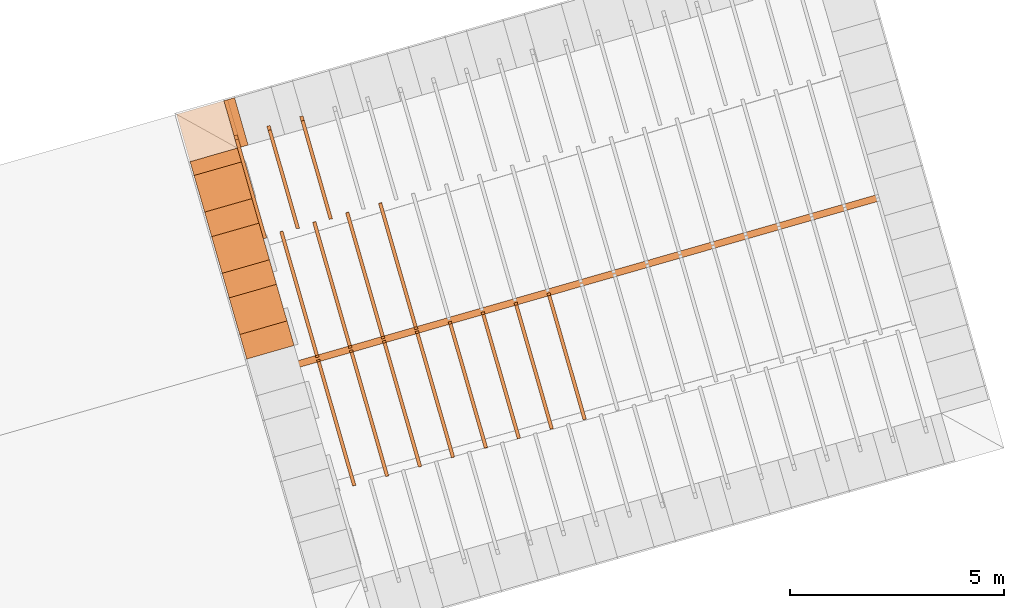
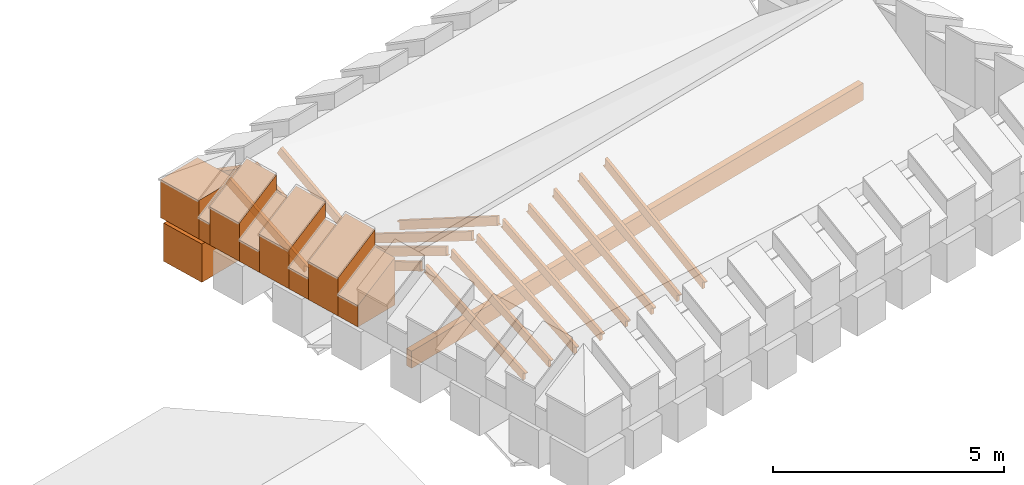
# One storey, part 6 of 10: 26 proxies.
"""IFC4 building model written with IfcOpenShell, lengths in metres."""

from ifc_helpers import new_model, entity, si_unit, converted_unit, derived_unit, direction, frame, origin_with_axes, place, context, subcontext, project, spatial, polygons, material, type_object, element, save


model = new_model("IFC4")

# Units and contexts
model_context = context("Model", 3, precision=1e-05, world=origin_with_axes(), true_north=direction((0.0, 1.0)))
body_context = subcontext(model_context, "Body", "Model", "MODEL_VIEW")
ifc_project = project(units=[si_unit("LENGTHUNIT", "METRE"), si_unit("AREAUNIT", "SQUARE_METRE"), si_unit("VOLUMEUNIT", "CUBIC_METRE"), converted_unit("PLANEANGLEUNIT", "DEGREE", entity("IfcPlaneAngleMeasure", 0.0174532925199433), si_unit("PLANEANGLEUNIT", "RADIAN"), dimensions=[0, 0, 0, 0, 0, 0, 0]), converted_unit("TIMEUNIT", "Year", entity("IfcTimeMeasure", 31557600.0), si_unit("TIMEUNIT", "SECOND"), dimensions=[0, 0, 1, 0, 0, 0, 0]), si_unit("MASSUNIT", "GRAM", prefix="KILO"), si_unit("THERMODYNAMICTEMPERATUREUNIT", "DEGREE_CELSIUS"), si_unit("LUMINOUSINTENSITYUNIT", "LUMEN"), si_unit("ENERGYUNIT", "JOULE", prefix="MEGA"), derived_unit("THERMALCONDUCTANCEUNIT", [(si_unit("POWERUNIT", "WATT"), 1), (si_unit("LENGTHUNIT", "METRE"), -1), (si_unit("THERMODYNAMICTEMPERATUREUNIT", "KELVIN"), -1)]), derived_unit("SPECIFICHEATCAPACITYUNIT", [(si_unit("ENERGYUNIT", "JOULE"), 1), (si_unit("MASSUNIT", "GRAM", prefix="KILO"), -1), (si_unit("THERMODYNAMICTEMPERATUREUNIT", "KELVIN"), -1)]), derived_unit("MASSDENSITYUNIT", [(si_unit("MASSUNIT", "GRAM", prefix="KILO"), 1), (si_unit("VOLUMEUNIT", "CUBIC_METRE"), -1)])], contexts=[model_context])

# Site, building, storey
site_placement = place(None, frame((0.0, 0.0, 0.0), z_axis=(0.0, 0.0, 1.0), x_axis=(0.9612616959383189, 0.2756373558169991, 0.0)))
site = spatial("IfcSite", under=ifc_project, at=site_placement, CompositionType="ELEMENT")
building_placement = place(site_placement, origin_with_axes())
building = spatial("IfcBuilding", under=site, at=building_placement, CompositionType="ELEMENT")
storey_placement = place(building_placement, frame((0.0, 0.0, 11.0), z_axis=(0.0, 0.0, 1.0), x_axis=(1.0, 0.0, 0.0)))
storey = spatial("IfcBuildingStorey", under=building, at=storey_placement, Name="Dach", CompositionType="ELEMENT", Elevation=11.0)

# Proxies
ifc_material_1 = material()
building_element_proxy_type_1 = type_object("IfcBuildingElementProxyType", PredefinedType="NOTDEFINED")
proxy_1_placement = place(storey_placement, frame((-32.67063236374476, 25.87969375484247, -11.3285), z_axis=(0.0, 0.0, 1.0), x_axis=(-1.0, 0.0, 0.0)))
element("IfcBuildingElementProxy", 1, at=proxy_1_placement, inside=storey, type_object=building_element_proxy_type_1, material=ifc_material_1, Name="008", PredefinedType="NOTDEFINED", context=body_context, shape_type="Tessellation", body=[
    polygons([(-50.63241932296884, 7.419849216181192, 12.26570100967694), (-50.63241932296884, 9.787341089745903, 10.94997509667636), (-50.63241932296884, 9.787341089745901, 11.13105505479244), (-50.63241932296884, 9.914397939064663, 11.13105505479244), (-50.63241932296884, 7.526718754969065, 12.458), (-50.71241932296884, 7.419849216181192, 12.26570100967694), (-50.71241932296883, 9.787341089745903, 10.94997509667636), (-50.71241932296883, 9.787341089745901, 11.12517725698404), (-50.71241932296884, 9.924974335264164, 11.12517725698404), (-50.71241932296884, 7.526718754969065, 12.458)], [[[1, 2, 3, 4, 5]], [[1, 6, 7, 2]], [[2, 7, 8, 3]], [[3, 8, 9, 4]], [[4, 9, 10, 5]], [[5, 10, 6, 1]], [[10, 9, 8, 7, 6]]], closed=True),
])
proxy_2_placement = place(storey_placement, frame((-32.67063236374477, 25.87969375484247, -11.3285), z_axis=(0.0, 0.0, 1.0), x_axis=(-1.0, 0.0, 0.0)))
element("IfcBuildingElementProxy", 2, at=proxy_2_placement, inside=storey, type_object=building_element_proxy_type_1, material=ifc_material_1, Name="008", PredefinedType="NOTDEFINED", context=body_context, shape_type="Tessellation", body=[
    polygons([(-49.83241932296884, 7.423389784873412, 12.2637755835664), (-49.83241932296883, 9.787341089745903, 11.00613425209013), (-49.83241932296883, 9.787341089745901, 11.18983303287644), (-49.83241932296884, 9.910454786615606, 11.18983303287644), (-49.83241932296884, 7.526718754969066, 12.458), (-49.91241932296884, 7.423389784873412, 12.2637755835664), (-49.91241932296883, 9.787341089745903, 11.00613425209013), (-49.91241932296883, 9.787341089745901, 11.18395523506804), (-49.91241932296884, 9.921503109735388, 11.18395523506804), (-49.91241932296884, 7.526718754969066, 12.458)], [[[1, 2, 3, 4, 5]], [[1, 6, 7, 2]], [[2, 7, 8, 3]], [[3, 8, 9, 4]], [[4, 9, 10, 5]], [[5, 10, 6, 1]], [[10, 9, 8, 7, 6]]], closed=True),
])
proxy_3_placement = place(storey_placement, frame((-32.67063236374477, 25.87969375484247, -11.3285), z_axis=(0.0, 0.0, 1.0), x_axis=(-1.0, 0.0, 0.0)))
element("IfcBuildingElementProxy", 3, at=proxy_3_placement, inside=storey, type_object=building_element_proxy_type_1, material=ifc_material_1, Name="008", PredefinedType="NOTDEFINED", context=body_context, shape_type="Tessellation", body=[
    polygons([(-49.03241932296884, 7.427506488142882, 12.26164082371529), (-49.03241932296884, 9.787341089745903, 11.06931284297234), (-49.03241932296884, 9.787341089745901, 11.24861101096044), (-49.03241932296884, 9.920320204592786, 11.24861101096044), (-49.03241932296884, 7.526718754969065, 12.458), (-49.11241932296884, 7.427506488142882, 12.26164082371529), (-49.11241932296884, 9.787341089745903, 11.06931284297234), (-49.11241932296884, 9.787341089745901, 11.24273321315204), (-49.11241932296884, 9.931953438798063, 11.24273321315204), (-49.11241932296884, 7.526718754969065, 12.458)], [[[1, 2, 3, 4, 5]], [[1, 6, 7, 2]], [[2, 7, 8, 3]], [[3, 8, 9, 4]], [[4, 9, 10, 5]], [[5, 10, 6, 1]], [[6, 10, 9, 8, 7]]], closed=True),
])
proxy_4_placement = place(storey_placement, frame((79.48385070717023, 25.8856182236699, -11.3285), z_axis=(0.0, 0.0, 1.0), x_axis=(-1.0, 0.0, 0.0)))
element("IfcBuildingElementProxy", 4, at=proxy_4_placement, inside=storey, type_object=building_element_proxy_type_1, material=ifc_material_1, Name="003", PredefinedType="NOTDEFINED", context=body_context, shape_type="Tessellation", body=[
    polygons([(62.63241932244962, 13.04734108974591, 12.42240354413239), (62.63241932244962, 13.04734108974591, 12.642), (62.63241932244962, 16.05704587116545, 11.22718140033185), (62.63241932244962, 16.06059439832945, 11.21266180463813), (62.63241932244962, 15.9873410897459, 11.21266180463813), (62.63241932244962, 15.9873410897459, 11.01685304929643), (62.63241932244962, 12.9973520933992, 12.42240354413239), (62.71241932244962, 13.04734108974591, 12.42240354413239), (62.71241932244962, 13.04734108974591, 12.642), (62.71241932244962, 16.05704587116545, 11.22718140033185), (62.71241932244962, 16.05915788965334, 11.21853960244654), (62.71241932244962, 15.9873410897459, 11.21853960244654), (62.71241932244962, 15.9873410897459, 11.01685304929643), (62.71241932244962, 12.9973520933992, 12.42240354413239)], [[[1, 2, 3, 4, 5, 6, 7]], [[2, 1, 8, 9]], [[3, 2, 9, 10]], [[4, 3, 10, 11]], [[5, 4, 11, 12]], [[6, 5, 12, 13]], [[6, 13, 14, 7]], [[1, 7, 14, 8]], [[10, 9, 8, 14, 13, 12, 11]]], closed=True),
])
proxy_5_placement = place(storey_placement, frame((79.48385070717022, 25.8856182236699, -11.3285), z_axis=(0.0, 0.0, 1.0), x_axis=(-1.0, 0.0, 0.0)))
element("IfcBuildingElementProxy", 5, at=proxy_5_placement, inside=storey, type_object=building_element_proxy_type_1, material=ifc_material_1, Name="003", PredefinedType="NOTDEFINED", context=body_context, shape_type="Tessellation", body=[
    polygons([(61.8324193224496, 13.04734108974591, 12.42240354413239), (61.83241932244962, 13.04734108974591, 12.642), (61.83241932244962, 16.05704587116544, 11.16933419402731), (61.83241932244962, 16.06056700055162, 11.15388382655413), (61.83241932244962, 15.9873410897459, 11.15388382655413), (61.83241932244962, 15.9873410897459, 10.95851680209063), (61.83241932244962, 12.99557818664126, 12.42240354413239), (61.91241932244962, 13.04734108974591, 12.42240354413239), (61.91241932244962, 13.04734108974591, 12.642), (61.91241932244962, 16.05704587116544, 11.16933419402731), (61.91241932244962, 16.05922745399229, 11.15976162436253), (61.91241932244964, 15.9873410897459, 11.15976162436253), (61.91241932244962, 15.9873410897459, 10.95851680209063), (61.91241932244962, 12.99557818664126, 12.42240354413239)], [[[1, 2, 3, 4, 5, 6, 7]], [[2, 1, 8, 9]], [[3, 2, 9, 10]], [[4, 3, 10, 11]], [[5, 4, 11, 12]], [[6, 5, 12, 13]], [[6, 13, 14, 7]], [[1, 7, 14, 8]], [[10, 9, 8, 14, 13, 12, 11]]], closed=True),
])
proxy_6_placement = place(storey_placement, frame((79.48385070717022, 25.8856182236699, -11.3285), z_axis=(0.0, 0.0, 1.0), x_axis=(-1.0, 0.0, 0.0)))
element("IfcBuildingElementProxy", 6, at=proxy_6_placement, inside=storey, type_object=building_element_proxy_type_1, material=ifc_material_1, Name="003", PredefinedType="NOTDEFINED", context=body_context, shape_type="Tessellation", body=[
    polygons([(61.03241932244959, 13.04734108974591, 12.42240354413239), (61.03241932244962, 13.04734108974591, 12.642), (61.03241932244962, 16.05704587116542, 11.11503282289326), (61.03241932244962, 16.06128522884663, 11.09510584847013), (61.03241932244962, 15.9873410897459, 11.09510584847013), (61.03241932244962, 15.9873410897459, 10.90370274711498), (61.03241932244962, 12.99392962756258, 12.42240354413239), (61.11241932244962, 13.04734108974591, 12.42240354413239), (61.11241932244962, 13.04734108974591, 12.642), (61.11241932244962, 16.05704587116542, 11.11503282289326), (61.11241932244962, 16.06003475866693, 11.10098364627853), (61.11241932244962, 15.9873410897459, 11.10098364627853), (61.11241932244962, 15.9873410897459, 10.90370274711498), (61.11241932244962, 12.99392962756258, 12.42240354413239)], [[[1, 2, 3, 4, 5, 6, 7]], [[2, 1, 8, 9]], [[3, 2, 9, 10]], [[4, 3, 10, 11]], [[5, 4, 11, 12]], [[6, 5, 12, 13]], [[6, 13, 14, 7]], [[1, 7, 14, 8]], [[10, 9, 8, 14, 13, 12, 11]]], closed=True),
])
proxy_7_placement = place(storey_placement, frame((79.48385070717022, 25.8856182236699, -11.3285), z_axis=(0.0, 0.0, 1.0), x_axis=(-1.0, 0.0, 0.0)))
element("IfcBuildingElementProxy", 7, at=proxy_7_placement, inside=storey, type_object=building_element_proxy_type_1, material=ifc_material_1, Name="003", PredefinedType="NOTDEFINED", context=body_context, shape_type="Tessellation", body=[
    polygons([(60.23241932244964, 13.04734108974591, 12.42240354413239), (60.23241932244962, 13.04734108974591, 12.642), (60.23241932244962, 16.0570458711654, 11.06407618241266), (60.23241932244962, 16.06256238857363, 11.03632787038613), (60.23241932244962, 15.9873410897459, 11.03632787038613), (60.23241932244962, 15.9873410897459, 10.85221878669346), (60.23241932244962, 12.99239765869873, 12.42240354413239), (60.31241932244962, 13.04734108974591, 12.42240354413239), (60.31241932244962, 13.04734108974591, 12.642), (60.31241932244962, 16.0570458711654, 11.06407618241266), (60.31241932244962, 16.06139384996483, 11.04220566819453), (60.31241932244962, 15.9873410897459, 11.04220566819453), (60.31241932244962, 15.9873410897459, 10.85221878669346), (60.31241932244962, 12.99239765869873, 12.42240354413239)], [[[1, 2, 3, 4, 5, 6, 7]], [[2, 1, 8, 9]], [[3, 2, 9, 10]], [[4, 3, 10, 11]], [[5, 4, 11, 12]], [[6, 5, 12, 13]], [[6, 13, 14, 7]], [[1, 7, 14, 8]], [[10, 9, 8, 14, 13, 12, 11]]], closed=True),
])
proxy_8_placement = place(storey_placement, frame((79.48385070717022, 25.8856182236699, -11.3285), z_axis=(0.0, 0.0, 1.0), x_axis=(-1.0, 0.0, 0.0)))
element("IfcBuildingElementProxy", 8, at=proxy_8_placement, inside=storey, type_object=building_element_proxy_type_1, material=ifc_material_1, Name="003", PredefinedType="NOTDEFINED", context=body_context, shape_type="Tessellation", body=[
    polygons([(59.43241932244963, 13.04734108974591, 12.42240354413239), (59.43241932244962, 13.04734108974591, 12.642), (59.43241932244962, 16.05704587116538, 11.01971375703324), (59.43241932244962, 16.06492572302275, 10.97754989230213), (59.43241932244962, 15.9873410897459, 10.97754989230213), (59.43241932244962, 15.9873410897459, 10.80736157550196), (59.43241932244962, 12.99107606176226, 12.42240354413239), (59.51241932244962, 13.04734108974591, 12.42240354413239), (59.51241932244962, 13.04734108974591, 12.642), (59.51241932244962, 16.05704587116538, 11.01971375703324), (59.51241932244962, 16.06382724269432, 10.98342769011053), (59.51241932244967, 15.9873410897459, 10.98342769011053), (59.51241932244962, 15.9873410897459, 10.80736157550196), (59.51241932244962, 12.99107606176226, 12.42240354413239)], [[[1, 2, 3, 4, 5, 6, 7]], [[2, 1, 8, 9]], [[3, 2, 9, 10]], [[4, 3, 10, 11]], [[5, 4, 11, 12]], [[6, 5, 12, 13]], [[6, 13, 14, 7]], [[1, 7, 14, 8]], [[10, 9, 8, 14, 13, 12, 11]]], closed=True),
])
proxy_9_placement = place(storey_placement, frame((79.48385070717022, 25.8856182236699, -11.3285), z_axis=(0.0, 0.0, 1.0), x_axis=(-1.0, 0.0, 0.0)))
element("IfcBuildingElementProxy", 9, at=proxy_9_placement, inside=storey, type_object=building_element_proxy_type_1, material=ifc_material_1, Name="003", PredefinedType="NOTDEFINED", context=body_context, shape_type="Tessellation", body=[
    polygons([(58.63241932244962, 13.04734108974591, 12.42240354413239), (58.63241932244962, 13.04734108974591, 12.642), (58.63241932244962, 16.05704587116536, 10.94616668750873), (58.63241932244962, 16.06163601740884, 10.91877191421813), (58.63241932244962, 15.9873410897459, 10.91877191421813), (58.63241932244962, 15.9873410897459, 10.73292267693545), (58.63241932244962, 12.98891040279966, 12.42240354413239), (58.71241932244962, 13.04734108974591, 12.42240354413239), (58.71241932244962, 13.04734108974591, 12.642), (58.71241932244962, 16.05704587116536, 10.94616668750873), (58.71241932244962, 16.06065115977765, 10.92464971202653), (58.71241932244962, 15.9873410897459, 10.92464971202653), (58.71241932244962, 15.9873410897459, 10.73292267693545), (58.71241932244962, 12.98891040279966, 12.42240354413239)], [[[1, 2, 3, 4, 5, 6, 7]], [[2, 1, 8, 9]], [[3, 2, 9, 10]], [[4, 3, 10, 11]], [[5, 4, 11, 12]], [[6, 5, 12, 13]], [[6, 13, 14, 7]], [[1, 7, 14, 8]], [[10, 9, 8, 14, 13, 12, 11]]], closed=True),
])
proxy_10_placement = place(storey_placement, frame((79.48385070717022, 25.8856182236699, -11.3285), z_axis=(0.0, 0.0, 1.0), x_axis=(-1.0, 0.0, 0.0)))
element("IfcBuildingElementProxy", 10, at=proxy_10_placement, inside=storey, type_object=building_element_proxy_type_1, material=ifc_material_1, Name="003", PredefinedType="NOTDEFINED", context=body_context, shape_type="Tessellation", body=[
    polygons([(57.83241932244969, 13.04734108974591, 12.42240354413239), (57.83241932244962, 13.04734108974591, 12.642), (57.83241932244962, 16.05704587116535, 10.88579983865006), (57.83241932244962, 16.06097033880345, 10.85999393613413), (57.83241932244962, 15.9873410897459, 10.85999393613413), (57.83241932244962, 15.9873410897459, 10.6717587829879), (57.83241932244962, 12.98715692842933, 12.42240354413239), (57.91241932244962, 13.04734108974591, 12.42240354413239), (57.91241932244962, 13.04734108974591, 12.642), (57.91241932244962, 16.05704587116535, 10.88579983865006), (57.91241932244962, 16.06007646472684, 10.86587173394253), (57.91241932244965, 15.9873410897459, 10.86587173394253), (57.91241932244962, 15.9873410897459, 10.6717587829879), (57.91241932244962, 12.98715692842933, 12.42240354413239)], [[[1, 2, 3, 4, 5, 6, 7]], [[2, 1, 8, 9]], [[3, 2, 9, 10]], [[4, 3, 10, 11]], [[5, 4, 11, 12]], [[6, 5, 12, 13]], [[6, 13, 14, 7]], [[1, 7, 14, 8]], [[10, 9, 8, 14, 13, 12, 11]]], closed=True),
])
proxy_11_placement = place(storey_placement, frame((79.48385070717022, 25.8856182236699, -11.3285), z_axis=(0.0, 0.0, 1.0), x_axis=(-1.0, 0.0, 0.0)))
element("IfcBuildingElementProxy", 11, at=proxy_11_placement, inside=storey, type_object=building_element_proxy_type_1, material=ifc_material_1, Name="003", PredefinedType="NOTDEFINED", context=body_context, shape_type="Tessellation", body=[
    polygons([(57.03241932244966, 13.0473410897459, 12.42240354413239), (57.03241932244962, 13.04734108974591, 12.642), (57.03241932244962, 16.05704587116533, 10.8236865752276), (57.03241932244962, 16.06011313379123, 10.80121595805013), (57.03241932244963, 15.9873410897459, 10.80121595805013), (57.03241932244962, 15.9873410897459, 10.60876590451085), (57.03241932244962, 12.9853757512264, 12.42240354413239), (57.11241932244962, 13.0473410897459, 12.42240354413239), (57.11241932244962, 13.04734108974591, 12.642), (57.11241932244962, 16.05704587116533, 10.8236865752276), (57.11241932244962, 16.0593108082744, 10.80709375585853), (57.11241932244967, 15.9873410897459, 10.80709375585853), (57.11241932244962, 15.9873410897459, 10.60876590451085), (57.11241932244962, 12.9853757512264, 12.42240354413239)], [[[1, 2, 3, 4, 5, 6, 7]], [[2, 1, 8, 9]], [[3, 2, 9, 10]], [[4, 3, 10, 11]], [[5, 4, 11, 12]], [[6, 5, 12, 13]], [[6, 13, 14, 7]], [[1, 7, 14, 8]], [[10, 9, 8, 14, 13, 12, 11]]], closed=True),
])
proxy_12_placement = place(storey_placement, frame((79.48385070717022, -0.05357057732701342, -11.3285), z_axis=(0.0, 0.0, 1.0), x_axis=(1.0, 0.0, 0.0)))
element("IfcBuildingElementProxy", 12, at=proxy_12_placement, inside=storey, type_object=building_element_proxy_type_1, material=ifc_material_1, Name="003", PredefinedType="NOTDEFINED", context=body_context, shape_type="Tessellation", body=[
    polygons([(-62.63241932244962, 13.04734108974591, 12.42240354413239), (-62.63241932244962, 12.9973520933992, 12.42240354413239), (-62.63241932244962, 15.9873410897459, 11.01685304929643), (-62.63241932244962, 15.9873410897459, 11.21266180463813), (-62.63241932244962, 16.06059439832945, 11.21266180463813), (-62.63241932244962, 16.05704587116545, 11.22718140033185), (-62.63241932244962, 13.04734108974591, 12.642), (-62.71241932244962, 13.04734108974591, 12.42240354413239), (-62.71241932244962, 12.9973520933992, 12.42240354413239), (-62.71241932244962, 15.9873410897459, 11.01685304929643), (-62.71241932244962, 15.9873410897459, 11.21853960244654), (-62.71241932244962, 16.05915788965334, 11.21853960244654), (-62.71241932244962, 16.05704587116545, 11.22718140033185), (-62.71241932244962, 13.04734108974591, 12.642)], [[[1, 2, 3, 4, 5, 6, 7]], [[1, 8, 9, 2]], [[3, 2, 9, 10]], [[3, 10, 11, 4]], [[4, 11, 12, 5]], [[5, 12, 13, 6]], [[6, 13, 14, 7]], [[7, 14, 8, 1]], [[13, 12, 11, 10, 9, 8, 14]]], closed=True),
])
proxy_13_placement = place(storey_placement, frame((79.48385070717022, -0.05357057732701342, -11.3285), z_axis=(0.0, 0.0, 1.0), x_axis=(1.0, 0.0, 0.0)))
element("IfcBuildingElementProxy", 13, at=proxy_13_placement, inside=storey, type_object=building_element_proxy_type_1, material=ifc_material_1, Name="003", PredefinedType="NOTDEFINED", context=body_context, shape_type="Tessellation", body=[
    polygons([(-61.8324193224496, 13.04734108974591, 12.42240354413239), (-61.83241932244962, 12.99557818664126, 12.42240354413239), (-61.83241932244962, 15.9873410897459, 10.95851680209063), (-61.83241932244962, 15.9873410897459, 11.15388382655413), (-61.83241932244962, 16.06056700055162, 11.15388382655413), (-61.83241932244962, 16.05704587116544, 11.16933419402731), (-61.83241932244962, 13.04734108974591, 12.642), (-61.91241932244962, 13.04734108974591, 12.42240354413239), (-61.91241932244962, 12.99557818664126, 12.42240354413239), (-61.91241932244962, 15.9873410897459, 10.95851680209063), (-61.91241932244964, 15.9873410897459, 11.15976162436253), (-61.91241932244962, 16.05922745399229, 11.15976162436253), (-61.91241932244962, 16.05704587116544, 11.16933419402731), (-61.91241932244962, 13.04734108974591, 12.642)], [[[1, 2, 3, 4, 5, 6, 7]], [[1, 8, 9, 2]], [[3, 2, 9, 10]], [[3, 10, 11, 4]], [[4, 11, 12, 5]], [[5, 12, 13, 6]], [[6, 13, 14, 7]], [[7, 14, 8, 1]], [[13, 12, 11, 10, 9, 8, 14]]], closed=True),
])
proxy_14_placement = place(storey_placement, frame((79.48385070717022, -0.05357057732701342, -11.3285), z_axis=(0.0, 0.0, 1.0), x_axis=(1.0, 0.0, 0.0)))
element("IfcBuildingElementProxy", 14, at=proxy_14_placement, inside=storey, type_object=building_element_proxy_type_1, material=ifc_material_1, Name="003", PredefinedType="NOTDEFINED", context=body_context, shape_type="Tessellation", body=[
    polygons([(-61.03241932244959, 13.04734108974591, 12.42240354413239), (-61.03241932244962, 12.99392962756258, 12.42240354413239), (-61.03241932244962, 15.9873410897459, 10.90370274711498), (-61.03241932244962, 15.9873410897459, 11.09510584847013), (-61.03241932244962, 16.06128522884663, 11.09510584847013), (-61.03241932244962, 16.05704587116542, 11.11503282289326), (-61.03241932244962, 13.04734108974591, 12.642), (-61.11241932244962, 13.04734108974591, 12.42240354413239), (-61.11241932244962, 12.99392962756258, 12.42240354413239), (-61.11241932244962, 15.9873410897459, 10.90370274711498), (-61.11241932244962, 15.9873410897459, 11.10098364627853), (-61.11241932244962, 16.06003475866693, 11.10098364627853), (-61.11241932244962, 16.05704587116542, 11.11503282289326), (-61.11241932244962, 13.04734108974591, 12.642)], [[[1, 2, 3, 4, 5, 6, 7]], [[1, 8, 9, 2]], [[3, 2, 9, 10]], [[3, 10, 11, 4]], [[4, 11, 12, 5]], [[5, 12, 13, 6]], [[6, 13, 14, 7]], [[7, 14, 8, 1]], [[13, 12, 11, 10, 9, 8, 14]]], closed=True),
])
proxy_15_placement = place(storey_placement, frame((79.48385070717022, -0.05357057732701342, -11.3285), z_axis=(0.0, 0.0, 1.0), x_axis=(1.0, 0.0, 0.0)))
element("IfcBuildingElementProxy", 15, at=proxy_15_placement, inside=storey, type_object=building_element_proxy_type_1, material=ifc_material_1, Name="003", PredefinedType="NOTDEFINED", context=body_context, shape_type="Tessellation", body=[
    polygons([(-60.23241932244964, 13.04734108974591, 12.42240354413239), (-60.23241932244962, 12.99239765869873, 12.42240354413239), (-60.23241932244962, 15.9873410897459, 10.85221878669346), (-60.23241932244962, 15.9873410897459, 11.03632787038613), (-60.23241932244962, 16.06256238857363, 11.03632787038613), (-60.23241932244962, 16.0570458711654, 11.06407618241266), (-60.23241932244962, 13.04734108974591, 12.642), (-60.31241932244962, 13.04734108974591, 12.42240354413239), (-60.31241932244962, 12.99239765869873, 12.42240354413239), (-60.31241932244962, 15.9873410897459, 10.85221878669346), (-60.31241932244962, 15.9873410897459, 11.04220566819453), (-60.31241932244962, 16.06139384996483, 11.04220566819453), (-60.31241932244962, 16.0570458711654, 11.06407618241266), (-60.31241932244962, 13.04734108974591, 12.642)], [[[1, 2, 3, 4, 5, 6, 7]], [[1, 8, 9, 2]], [[3, 2, 9, 10]], [[3, 10, 11, 4]], [[4, 11, 12, 5]], [[5, 12, 13, 6]], [[6, 13, 14, 7]], [[7, 14, 8, 1]], [[13, 12, 11, 10, 9, 8, 14]]], closed=True),
])
ifc_material_2 = material(Name="Aluminium")
building_element_proxy_type_2 = type_object("IfcBuildingElementProxyType", Name="Aluminium", PredefinedType="NOTDEFINED")
proxy_16_placement = place(storey_placement, frame((16.34406075671145, 12.99607052434882, -1.206782428685756), z_axis=(0.0, 0.0, 1.0), x_axis=(1.0, 0.0, 0.0)))
element("IfcBuildingElementProxy", 16, at=proxy_16_placement, inside=storey, type_object=building_element_proxy_type_2, material=ifc_material_2, Name="001", PredefinedType="NOTDEFINED", context=body_context, shape_type="Tessellation", body=[
    polygons([(0.0, -0.1600000000826221, 0.0), (14.08857514171309, -0.1600000000826221, 0.0), (14.08857514171309, -0.1600000000826221, 0.4521338064115614), (0.0, -0.1600000000826221, 0.4521338064115614), (0.0, 0.0, 0.0), (14.08857514171309, 0.0, 0.0), (14.08857514171309, 0.0, 0.4521338064115614), (0.0, 0.0, 0.4521338064115614)], [[[1, 2, 3, 4]], [[1, 5, 6, 2]], [[2, 6, 7, 3]], [[8, 4, 3, 7]], [[5, 1, 4, 8]], [[6, 5, 8, 7]]], closed=True),
])
ifc_material_3 = material()
building_element_proxy_type_3 = type_object("IfcBuildingElementProxyType", Name="336 x 1150", PredefinedType="NOTDEFINED")
proxy_17_placement = place(storey_placement, frame((15.78785962167053, 17.98844362135029, 0.2019994076779685), z_axis=(0.0, 0.0, 1.0), x_axis=(1.851628352347186e-10, -1.0, 0.0)))
element("IfcBuildingElementProxy", 17, at=proxy_17_placement, inside=storey, type_object=building_element_proxy_type_3, material=ifc_material_3, PredefinedType="NOTDEFINED", context=body_context, shape_type="Tessellation", body=[
    polygons([(0.168202757876692, 0.5750000000000011, 1.258340042868717), (0.168202757876692, 0.5750000000000011, 0.0), (-0.168202757876692, 0.5750000000000011, 0.0), (-0.168202757876692, 0.5750000000000011, 1.258340042868717), (0.168202757876692, -0.5749999999999993, 0.5616599571312832), (0.168202757876692, -0.5749999999999993, 0.0), (-0.168202757876692, -0.5749999999999993, 0.0), (-0.168202757876692, -0.5749999999999993, 0.5616599571312832)], [[[1, 2, 3, 4]], [[5, 6, 2, 1]], [[3, 2, 6, 7]], [[4, 3, 7, 8]], [[5, 1, 4, 8]], [[8, 7, 6, 5]]], closed=True),
])
building_element_proxy_type_4 = type_object("IfcBuildingElementProxyType", Name="259 x 1150", PredefinedType="NOTDEFINED")
proxy_18_placement = place(storey_placement, frame((16.49234043874521, 18.73164613209288, 0.2019994110307355), z_axis=(0.0, 0.0, 1.0), x_axis=(-1.0, -4.799646136429001e-09, 0.0)))
element("IfcBuildingElementProxy", 18, at=proxy_18_placement, inside=storey, type_object=building_element_proxy_type_4, material=ifc_material_3, PredefinedType="NOTDEFINED", context=body_context, shape_type="Tessellation", body=[
    polygons([(0.1294808085213504, 0.5749999999999993, 1.258340042868717), (0.1294808085213504, 0.5749999999999993, 0.0), (-0.1294808085213468, 0.5749999999999993, 0.0), (-0.1294808085213468, 0.5749999999999993, 1.258340042868717), (0.1294808085213504, -0.5749999999999993, 0.5616599571312832), (0.1294808085213504, -0.5749999999999993, 0.0), (-0.1294808085213468, -0.5749999999999993, 0.0), (-0.1294808085213468, -0.5749999999999993, 0.5616599571312832)], [[[1, 2, 3, 4]], [[5, 6, 2, 1]], [[3, 2, 6, 7]], [[4, 3, 7, 8]], [[5, 1, 4, 8]], [[8, 7, 6, 5]]], closed=True),
])
building_element_proxy_type_5 = type_object("IfcBuildingElementProxyType", Name="1150 x 1150", PredefinedType="NOTDEFINED")
proxy_19_placement = place(storey_placement, frame((15.78785962699888, 18.73164613147143, 0.2019994110307373), z_axis=(0.0, 0.0, 1.0), x_axis=(0.0, 1.0, 0.0)))
element("IfcBuildingElementProxy", 19, at=proxy_19_placement, inside=storey, type_object=building_element_proxy_type_5, material=ifc_material_3, PredefinedType="NOTDEFINED", context=body_context, shape_type="Tessellation", body=[
    polygons([(-0.5749999999999993, -0.5750000000000011, 1.011699999999999), (-0.5749999999999993, -0.5750000000000011, 0.0), (0.5749999999999993, -0.5749999999999975, 0.0), (0.5749999999999993, -0.5749999999999975, 1.011699999999999), (-0.5749999999999993, 0.5750000000000011, 1.011699999999999), (-0.5749999999999993, 0.5750000000000011, 0.0), (0.5749999999999993, 0.5750000000000011, 0.0), (0.5749999999999993, 0.5750000000000011, 1.011699999999999)], [[[1, 2, 3, 4]], [[5, 6, 2, 1]], [[3, 2, 6, 7]], [[4, 3, 7, 8]], [[5, 1, 4, 8]], [[8, 7, 6, 5]]], closed=True),
])
building_element_proxy_type_6 = type_object("IfcBuildingElementProxyType", Name="596 x 1150", PredefinedType="NOTDEFINED")
proxy_20_placement = place(storey_placement, frame((15.7878596267256, 16.63203833713904, 0.2019994076779685), z_axis=(0.0, 0.0, 1.0), x_axis=(1.851628352347186e-10, -1.0, 0.0)))
element("IfcBuildingElementProxy", 20, at=proxy_20_placement, inside=storey, type_object=building_element_proxy_type_6, material=ifc_material_3, PredefinedType="NOTDEFINED", context=body_context, shape_type="Tessellation", body=[
    polygons([(0.2981999999999978, 0.5749999999999975, 1.258340042868717), (0.2981999999999978, 0.5749999999999975, 0.0), (-0.2982000000000014, 0.5749999999999975, 0.0), (-0.2982000000000014, 0.5749999999999975, 1.258340042868717), (0.2982000000000014, -0.5750000000000011, 0.5616599571312832), (0.2982000000000014, -0.5750000000000011, 0.0), (-0.2981999999999978, -0.5750000000000011, 0.0), (-0.2981999999999978, -0.5750000000000011, 0.5616599571312832)], [[[1, 2, 3, 4]], [[5, 6, 2, 1]], [[3, 2, 6, 7]], [[4, 3, 7, 8]], [[5, 1, 4, 8]], [[8, 7, 6, 5]]], closed=True),
])
proxy_21_placement = place(storey_placement, frame((15.78785962681922, 15.14563253159531, 0.2019994076779685), z_axis=(0.0, 0.0, 1.0), x_axis=(1.851628352347186e-10, -1.0, 0.0)))
element("IfcBuildingElementProxy", 21, at=proxy_21_placement, inside=storey, type_object=building_element_proxy_type_6, material=ifc_material_3, PredefinedType="NOTDEFINED", context=body_context, shape_type="Tessellation", body=[
    polygons([(0.2981999999999996, 0.5750000000000011, 1.258340042868717), (0.2981999999999996, 0.5750000000000011, 0.0), (-0.2982000000000014, 0.5750000000000011, 0.0), (-0.2982000000000014, 0.5750000000000011, 1.258340042868717), (0.2981999999999996, -0.5749999999999993, 0.5616599571312832), (0.2981999999999996, -0.5749999999999993, 0.0), (-0.2982000000000014, -0.5749999999999993, 0.0), (-0.2982000000000014, -0.5749999999999993, 0.5616599571312832)], [[[1, 2, 3, 4]], [[5, 6, 2, 1]], [[3, 2, 6, 7]], [[4, 3, 7, 8]], [[5, 1, 4, 8]], [[8, 7, 6, 5]]], closed=True),
])
proxy_22_placement = place(storey_placement, frame((15.78785962691284, 13.65922672605158, 0.2019994076779685), z_axis=(0.0, 0.0, 1.0), x_axis=(1.851628352347186e-10, -1.0, 0.0)))
element("IfcBuildingElementProxy", 22, at=proxy_22_placement, inside=storey, type_object=building_element_proxy_type_6, material=ifc_material_3, PredefinedType="NOTDEFINED", context=body_context, shape_type="Tessellation", body=[
    polygons([(0.2981999999999996, 0.5749999999999993, 1.258340042868717), (0.2981999999999996, 0.5749999999999993, 0.0), (-0.2982000000000014, 0.5749999999999993, 0.0), (-0.2982000000000014, 0.5749999999999993, 1.258340042868717), (0.2981999999999996, -0.5749999999999993, 0.5616599571312832), (0.2981999999999996, -0.5749999999999993, 0.0), (-0.2982000000000014, -0.5749999999999993, 0.0), (-0.2982000000000014, -0.5749999999999993, 0.5616599571312832)], [[[1, 2, 3, 4]], [[5, 6, 2, 1]], [[3, 2, 6, 7]], [[4, 3, 7, 8]], [[5, 1, 4, 8]], [[8, 7, 6, 5]]], closed=True),
])
building_element_proxy_type_7 = type_object("IfcBuildingElementProxyType", Name="890 x 1150", PredefinedType="NOTDEFINED")
proxy_23_placement = place(storey_placement, frame((15.78785962658799, 17.37523961798664, 0.2019994076779703), z_axis=(0.0, 0.0, 1.0), x_axis=(1.851370780605473e-10, -1.0, 0.0)))
element("IfcBuildingElementProxy", 23, at=proxy_23_placement, inside=storey, type_object=building_element_proxy_type_7, material=ifc_material_3, PredefinedType="NOTDEFINED", context=body_context, shape_type="Tessellation", body=[
    polygons([(0.4450012808476238, 0.5749999999999993, 1.708340042868718), (0.4450012808476238, 0.5749999999999993, 0.0), (-0.4450012808476238, 0.5750000000000028, 0.0), (-0.4450012808476238, 0.5750000000000028, 1.708340042868718), (0.4450012808476238, -0.5749999999999993, 1.011659957131284), (0.4450012808476238, -0.5749999999999993, 0.0), (-0.4450012808476238, -0.5750000000000011, 0.0), (-0.4450012808476238, -0.5750000000000011, 1.011659957131284)], [[[1, 2, 3, 4]], [[5, 6, 2, 1]], [[3, 2, 6, 7]], [[4, 3, 7, 8]], [[5, 1, 4, 8]], [[8, 7, 6, 5]]], closed=True),
])
proxy_24_placement = place(storey_placement, frame((15.78785962671188, 15.88883435308433, 0.2019994076779703), z_axis=(0.0, 0.0, 1.0), x_axis=(1.851370780605473e-10, -1.0, 0.0)))
element("IfcBuildingElementProxy", 24, at=proxy_24_placement, inside=storey, type_object=building_element_proxy_type_7, material=ifc_material_3, PredefinedType="NOTDEFINED", context=body_context, shape_type="Tessellation", body=[
    polygons([(0.4450012808476238, 0.5750000000000011, 1.708340042868718), (0.4450012808476238, 0.5750000000000011, 0.0), (-0.4450012808476274, 0.5750000000000011, 0.0), (-0.4450012808476274, 0.5750000000000011, 1.708340042868718), (0.4450012808476238, -0.5750000000000011, 1.011659957131284), (0.4450012808476238, -0.5750000000000011, 0.0), (-0.4450012808476274, -0.5750000000000011, 0.0), (-0.4450012808476274, -0.5750000000000011, 1.011659957131284)], [[[1, 2, 3, 4]], [[5, 6, 2, 1]], [[3, 2, 6, 7]], [[4, 3, 7, 8]], [[5, 1, 4, 8]], [[8, 7, 6, 5]]], closed=True),
])
proxy_25_placement = place(storey_placement, frame((15.78785962683577, 14.40242908818201, 0.2019994076779703), z_axis=(0.0, 0.0, 1.0), x_axis=(1.851370780605473e-10, -1.0, 0.0)))
element("IfcBuildingElementProxy", 25, at=proxy_25_placement, inside=storey, type_object=building_element_proxy_type_7, material=ifc_material_3, PredefinedType="NOTDEFINED", context=body_context, shape_type="Tessellation", body=[
    polygons([(0.4450012808476238, 0.5750000000000011, 1.708340042868718), (0.4450012808476238, 0.5750000000000011, 0.0), (-0.4450012808476256, 0.5750000000000011, 0.0), (-0.4450012808476256, 0.5750000000000011, 1.708340042868718), (0.4450012808476238, -0.5749999999999993, 1.011659957131284), (0.4450012808476238, -0.5749999999999993, 0.0), (-0.4450012808476256, -0.5750000000000011, 0.0), (-0.4450012808476256, -0.5750000000000011, 1.011659957131284)], [[[1, 2, 3, 4]], [[5, 6, 2, 1]], [[3, 2, 6, 7]], [[4, 3, 7, 8]], [[5, 1, 4, 8]], [[8, 7, 6, 5]]], closed=True),
])
building_element_proxy_type_8 = type_object("IfcBuildingElementProxyType", PredefinedType="NOTDEFINED")
proxy_26_placement = place(storey_placement, frame((34.61754837703543, 2.944620357486031, -31.0), z_axis=(0.0, 0.0, 1.0), x_axis=(-4.318712482032093e-05, 0.9999999990674362, 0.0)))
element("IfcBuildingElementProxy", 26, at=proxy_26_placement, inside=storey, type_object=building_element_proxy_type_8, material=ifc_material_3, PredefinedType="NOTDEFINED", context=body_context, shape_type="Tessellation", body=[
    polygons([(15.21285962276114, 18.15664613147143, 30.0), (15.21285962276111, 19.30664613147142, 30.0), (16.36285962276111, 19.30664613147146, 30.0), (16.36285962276114, 18.15664613147147, 30.0), (15.21285962276114, 18.15664613147143, 31.0117), (15.21285962276111, 19.30664613147142, 31.0117), (16.36285962276111, 19.30664613147146, 31.0117), (16.36285962276114, 18.15664613147147, 31.0117)], [[[1, 2, 3, 4]], [[1, 5, 6, 2]], [[2, 6, 7, 3]], [[4, 3, 7, 8]], [[5, 1, 4, 8]], [[5, 8, 7, 6]]], closed=True),
])

save(model, "model.ifc")
